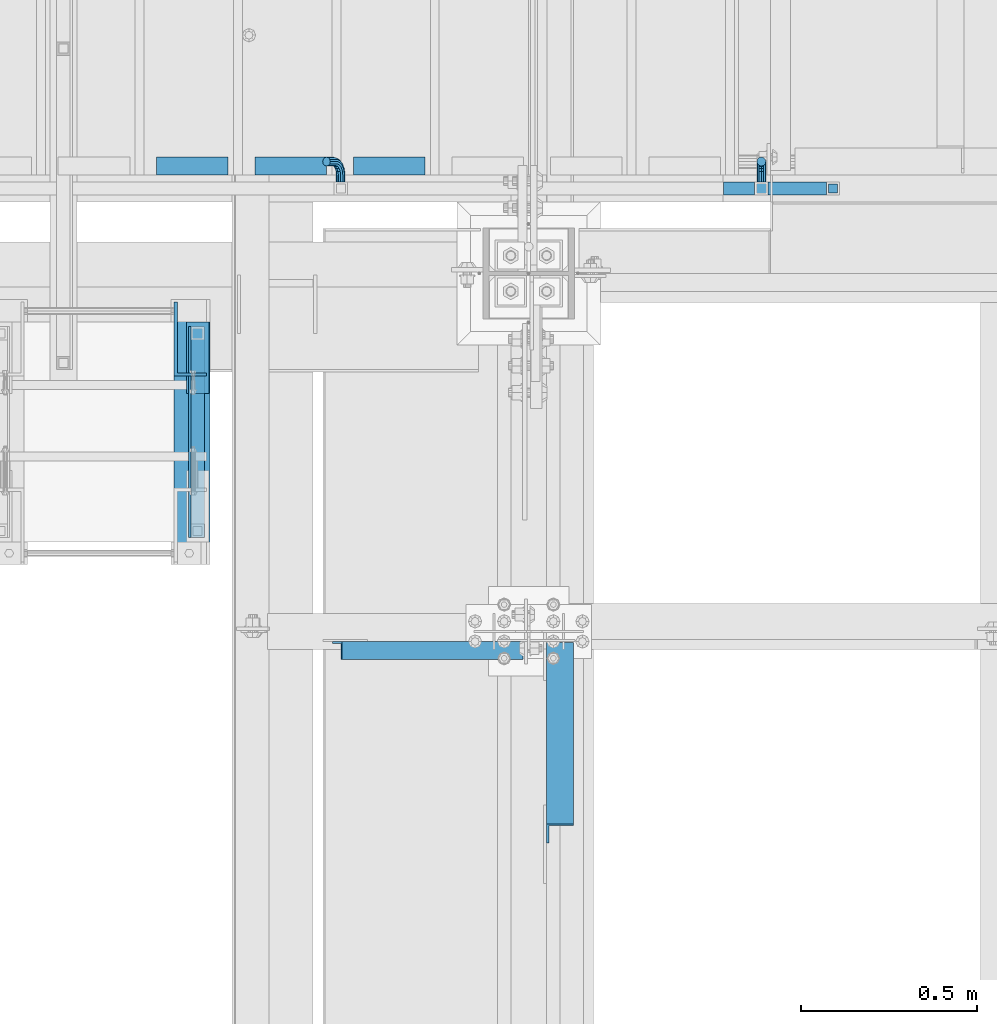
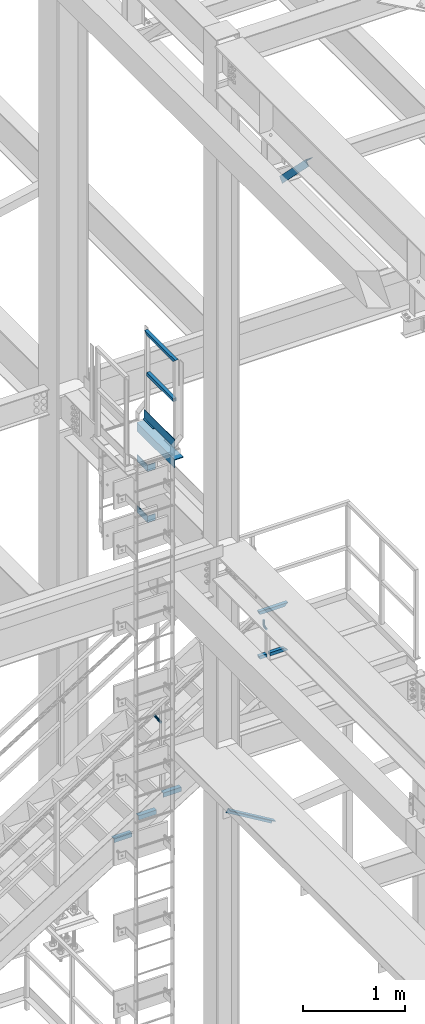
# One storey, part 2415 of 3843: 15 beams, 2 members, 7 elements without a shape of their own.
"""IFC2X3 building model written with IfcOpenShell, lengths in millimetres."""

from ifc_helpers import new_model, si_unit, frame, origin_with_axes, place, context, subcontext, project, spatial, faceted_brep, material, type_object, element, aggregate, save


model = new_model("IFC2X3")

# Units and contexts
model_context = context("Model", 3, precision=1e-05, world=origin_with_axes())
body_context = subcontext(model_context, "Body", "Model", "MODEL_VIEW")
ifc_project = project(units=[si_unit("LENGTHUNIT", "METRE", prefix="MILLI"), si_unit("AREAUNIT", "SQUARE_METRE"), si_unit("VOLUMEUNIT", "CUBIC_METRE"), si_unit("MASSUNIT", "GRAM", prefix="KILO"), si_unit("TIMEUNIT", "SECOND"), si_unit("PLANEANGLEUNIT", "RADIAN"), si_unit("SOLIDANGLEUNIT", "STERADIAN"), si_unit("THERMODYNAMICTEMPERATUREUNIT", "DEGREE_CELSIUS"), si_unit("LUMINOUSINTENSITYUNIT", "LUMEN")], contexts=[model_context])

# Site, building, storey
site_placement = place(None, origin_with_axes())
site = spatial("IfcSite", under=ifc_project, at=site_placement, CompositionType="ELEMENT")
building_placement = place(site_placement, origin_with_axes())
building = spatial("IfcBuilding", under=site, at=building_placement, Name="Undefined", CompositionType="ELEMENT")
storey_placement = place(building_placement, origin_with_axes())
storey = spatial("IfcBuildingStorey", under=building, at=storey_placement, Name="Undefined", CompositionType="ELEMENT", Elevation=0.0)

# Assembly, beams
assembly_1_placement = place(storey_placement, origin_with_axes())
assembly_1 = element("IfcElementAssembly", 1, at=assembly_1_placement, inside=storey, Name="LADDER", AssemblyPlace="NOTDEFINED", PredefinedType="RIGID_FRAME")
ifc_material_1 = material(Name="STEEL/A36")
beam_type_1 = type_object("IfcBeamType", PredefinedType="NOTDEFINED")
beam_1_placement = place(assembly_1_placement, frame((35574.2876302633, 89034.2801012867, 37797.6391357422), z_axis=(0.0, 0.0, 1.0), x_axis=(0.0, -1.0, 0.0)))
beam_1 = element("IfcBeam", 2, at=beam_1_placement, type_object=beam_type_1, material=ifc_material_1, Name="BENT_PLATE", context=body_context, shape_type="Brep", body=[
    faceted_brep([(0.0, -4.76250000000073, -38.0999999999985), (0.0, -4.76250000000073, 38.0999999999985), (0.0, 4.76250000000073, 38.0999999999985), (0.0, 4.76250000000073, -38.0999999999985), (200.223549612929, 4.76250007911585, 38.0999999999985), (200.223549612929, 4.76250007911585, -38.0999999999985), (209.748542611997, -4.76249991712393, -38.0999999999985), (209.748542611997, -4.76249991712393, 38.0999999999985), (200.223610287765, 87.3125000810978, 38.0999999999985), (200.223610287765, 87.3125000810978, -38.0999999999985), (209.748610287759, 87.3124930801496, 38.0999999999985), (209.748610287759, 87.3124930801496, -38.0999999999985)], [[[0, 1, 2, 3]], [[3, 2, 4, 5]], [[1, 0, 6, 7]], [[5, 4, 8, 9]], [[4, 2, 1, 7, 10, 8]], [[7, 6, 11, 10]], [[6, 0, 3, 5, 9, 11]], [[10, 11, 9, 8]]]),
])
beam_2_placement = place(assembly_1_placement, frame((35574.2876302804, 89034.2771574651, 37188.0390686035), z_axis=(0.0, 0.0, 1.0), x_axis=(0.0, -1.0, 0.0)))
beam_2 = element("IfcBeam", 3, at=beam_2_placement, type_object=beam_type_1, material=ifc_material_1, Name="BENT_PLATE", context=body_context, shape_type="Brep", body=[
    faceted_brep([(0.0, -4.76250000000073, -38.0999999999985), (0.0, -4.76250000000073, 38.0999999999985), (0.0, 4.76250000000073, 38.0999999999985), (0.0, 4.76250000000073, -38.0999999999985), (200.220605791415, 4.7625000627304, 38.0999999999985), (200.220605791415, 4.7625000627304, -38.0999999999985), (209.745598790527, -4.76249993429519, -38.0999999999985), (209.745598790527, -4.76249993429519, 38.0999999999985), (200.220666465641, 87.3125000643849, 38.0999999999985), (200.220666465641, 87.3125000643849, -38.0999999999985), (209.74566646562, 87.3124930635167, 38.0999999999985), (209.74566646562, 87.3124930635167, -38.0999999999985)], [[[0, 1, 2, 3]], [[3, 2, 4, 5]], [[1, 0, 6, 7]], [[5, 4, 8, 9]], [[4, 2, 1, 7, 10, 8]], [[7, 6, 11, 10]], [[6, 0, 3, 5, 9, 11]], [[10, 11, 9, 8]]]),
])
aggregate(assembly_1, [beam_1, beam_2])

assembly_2_placement = place(storey_placement, origin_with_axes())
assembly_2 = element("IfcElementAssembly", 4, at=assembly_2_placement, inside=storey, Name="RAIL", AssemblyPlace="NOTDEFINED", PredefinedType="RIGID_FRAME")
ifc_material_2 = material()
beam_type_2 = type_object("IfcBeamType", Name="HSS1-1/2X1-1/2X1/4", PredefinedType="NOTDEFINED")
beam_3_placement = place(assembly_2_placement, frame((35636.2, 88385.4515620002, 38851.6812479483), z_axis=(1.0, 0.0, 0.0), x_axis=(0.0, 1.0, 0.0)))
beam_3 = element("IfcBeam", 5, at=beam_3_placement, type_object=beam_type_2, material=ifc_material_2, Name="RAIL", ObjectType="HSS1-1/2X1-1/2X1/4", context=body_context, shape_type="Brep", body=[
    faceted_brep([(18.978796181982, 12.6999993299978, -12.6999993299978), (18.978796181982, -12.6999993299978, -12.6999993299978), (541.650771072775, -12.6999993299978, -12.6999993299978), (541.650771072775, 12.6999993299978, -12.6999993299978), (18.978796181982, -12.6999993299978, 12.6999993299978), (541.650771072775, -12.6999993299978, 12.6999993299978), (18.978796181982, 12.6999993299978, 12.6999993299978), (541.650771072775, 12.6999993299978, 12.6999993299978), (18.978796181982, 19.0499992350015, -19.0499992350015), (18.978796181982, 19.0499992350015, 19.0499992350015), (541.650771072775, 19.0499992350015, 19.0499992350015), (541.650771072775, 19.0499992350015, -19.0499992350015), (18.978796181982, -19.0499992350015, 19.0499992350015), (541.650771072775, -19.0499992350015, 19.0499992350015), (18.978796181982, -19.0499992350015, -19.0499992350015), (541.650771072775, -19.0499992350015, -19.0499992350015)], [[[0, 1, 2, 3]], [[1, 4, 5, 2]], [[4, 6, 7, 5]], [[6, 0, 3, 7]], [[8, 9, 10, 11]], [[9, 12, 13, 10]], [[12, 14, 15, 13]], [[14, 8, 11, 15]], [[13, 15, 11, 10], [5, 7, 3, 2]], [[14, 12, 9, 8], [6, 4, 1, 0]]]),
])
beam_4_placement = place(assembly_2_placement, frame((35636.2, 88385.4515620002, 39333.6859349483), z_axis=(1.0, 0.0, 0.0), x_axis=(0.0, 1.0, 0.0)))
beam_4 = element("IfcBeam", 6, at=beam_4_placement, type_object=beam_type_2, material=ifc_material_2, Name="RAIL", ObjectType="HSS1-1/2X1-1/2X1/4", context=body_context, shape_type="Brep", body=[
    faceted_brep([(-12.7712023829808, 12.6999993299978, -12.6999993299978), (12.6287962770293, -12.6999993299978, -12.6999993299978), (548.0007709778, -12.6999993299978, -12.6999993299978), (573.40076963781, 12.6999993299978, -12.6999993299978), (12.6287962770293, -12.6999993299978, 12.6999993299978), (548.0007709778, -12.6999993299978, 12.6999993299978), (-12.7712023829808, 12.6999993299978, 12.6999993299978), (573.40076963781, 12.6999993299978, 12.6999993299978), (-19.1212022879772, 19.0499992350015, -19.0499992350015), (-19.1212022879772, 19.0499992350015, 19.0499992350015), (579.750769542807, 19.0499992350015, 19.0499992350015), (579.750769542807, 19.0499992350015, -19.0499992350015), (18.978796181982, -19.0499992350015, 19.0499992350015), (541.650771072775, -19.0499992350015, 19.0499992350015), (18.978796181982, -19.0499992350015, -19.0499992350015), (541.650771072775, -19.0499992350015, -19.0499992350015)], [[[0, 1, 2, 3]], [[1, 4, 5, 2]], [[4, 6, 7, 5]], [[6, 0, 3, 7]], [[8, 9, 10, 11]], [[9, 12, 13, 10]], [[12, 14, 15, 13]], [[14, 8, 11, 15]], [[13, 15, 11, 10], [5, 7, 3, 2]], [[14, 12, 9, 8], [6, 4, 1, 0]]]),
])

assembly_3_placement = place(storey_placement, origin_with_axes())
assembly_3 = element("IfcElementAssembly", 7, at=assembly_3_placement, inside=storey, Name="RAIL", AssemblyPlace="NOTDEFINED", PredefinedType="RIGID_FRAME")
beam_5_placement = place(assembly_3_placement, frame((37236.4000002307, 89357.2000000455, 34670.999999695), z_axis=(0.0, 0.0, 1.0), x_axis=(1.0, 0.0, 0.0)))
beam_5 = element("IfcBeam", 8, at=beam_5_placement, type_object=beam_type_2, material=ifc_material_2, Name="RAIL", ObjectType="HSS1-1/2X1-1/2X1/4", context=body_context, shape_type="Brep", body=[
    faceted_brep([(19.0499992350015, 12.6999993299978, -12.6999993299978), (19.0499992350015, -12.6999993299978, -12.6999993299978), (215.899999329988, -12.6999993299978, -12.6999993299978), (215.899999329988, 12.6999993299978, -12.6999993299978), (19.0499992350015, -12.6999993299978, 12.6999993299978), (190.500000669992, -12.6999993299978, 12.6999993299978), (19.0499992350015, 12.6999993299978, 12.6999993299978), (190.500000669992, 12.6999993299978, 12.6999993299978), (19.0499992350015, 19.0499992350015, -19.0499992350015), (19.0499992350015, 19.0499992350015, 19.0499992350015), (184.150000764988, 19.0499992349942, 19.0499992350015), (222.249999234991, 19.0499992349942, -19.0499992350015), (19.0499992350015, -19.0499992350015, 19.0499992350015), (184.150000764988, -19.0499992349942, 19.0499992350015), (19.0499992350015, -19.0499992350015, -19.0499992350015), (222.249999234991, -19.0499992349942, -19.0499992350015)], [[[0, 1, 2, 3]], [[1, 4, 5, 2]], [[4, 6, 7, 5]], [[6, 0, 3, 7]], [[8, 9, 10, 11]], [[9, 12, 13, 10]], [[12, 14, 15, 13]], [[14, 8, 11, 15]], [[13, 15, 11, 10], [5, 7, 3, 2]], [[14, 12, 9, 8], [6, 4, 1, 0]]]),
])
beam_6_placement = place(assembly_3_placement, frame((37134.8000002412, 89357.2000000455, 34670.999999695), z_axis=(0.0, 0.0, 1.0), x_axis=(1.0, 0.0, 0.0)))
beam_6 = element("IfcBeam", 9, at=beam_6_placement, type_object=beam_type_2, material=ifc_material_2, Name="RAIL", ObjectType="HSS1-1/2X1-1/2X1/4", context=body_context, shape_type="Brep", body=[
    faceted_brep([(82.5500000532629, -19.0499999999993, 19.0499992350015), (82.5500000532629, -19.0499992350015, -19.0499992350015), (82.5500000532629, 19.0499992350015, -19.0499992350015), (82.5500000532629, 19.0499992350015, 19.0499992350015), (82.5500000532629, -12.6999993300014, 12.6999993299978), (82.5500000532629, 12.6999993300014, 12.6999993299978), (82.5500000532629, 12.6999993300014, -12.6999993299978), (82.5500000532629, -12.6999993300014, -12.6999993299978), (-5.45142736178605, 19.0499992350015, 19.0499992350015), (-5.45142736178605, -19.0499992350015, 19.0499992350015), (5.45142728947758, -19.0499992350015, -19.0499992350015), (5.45142728947758, 19.0499992350015, -19.0499992350015), (-3.63428487412239, 12.6999993299978, 12.6999993299978), (-3.63428487412239, -12.6999993299978, 12.6999993299978), (3.63428480181392, -12.6999993299978, -12.6999993299978), (3.63428480181392, 12.6999993299978, -12.6999993299978)], [[[0, 1, 2, 3], [4, 5, 6, 7]], [[8, 9, 0, 3]], [[10, 11, 2, 1]], [[9, 10, 1, 0]], [[11, 8, 3, 2]], [[10, 9, 8, 11], [12, 13, 14, 15]], [[14, 13, 4, 7]], [[15, 14, 7, 6]], [[12, 15, 6, 5]], [[13, 12, 5, 4]]]),
])
beam_7_placement = place(assembly_3_placement, frame((37439.6000002307, 89357.2000000455, 35204.399999695), z_axis=(0.0, 0.0, -1.0), x_axis=(-1.0, 0.0, 0.0)))
beam_7 = element("IfcBeam", 10, at=beam_7_placement, type_object=beam_type_2, material=ifc_material_2, Name="RAIL", ObjectType="HSS1-1/2X1-1/2X1/4", context=body_context, shape_type="Brep", body=[
    faceted_brep([(-12.6999993309546, 12.6999993299978, -12.6999993299978), (-12.6999993309546, -12.6999993299978, -12.6999993299978), (308.434284821327, -12.6999993299978, -12.6999993299978), (308.434284821327, 12.6999993299978, -12.6999993299978), (12.6999993290483, -12.6999993299978, 12.6999993299978), (301.165715145398, -12.6999993299978, 12.6999993299978), (12.6999993290483, 12.6999993299978, 12.6999993299978), (301.165715145398, 12.6999993299978, 12.6999993299978), (-19.0499992359546, 19.0499992350015, -19.0499992350015), (19.0499992350015, 19.0499992350015, 19.0499992350015), (299.348572657735, 19.0499992349942, 19.0499992350015), (310.251427308991, 19.0499992349942, -19.0499992350015), (19.0499992350015, -19.0499992350015, 19.0499992350015), (299.348572657735, -19.0499992349942, 19.0499992350015), (-19.0499992359546, -19.0499992350015, -19.0499992350015), (310.251427308991, -19.0499992349942, -19.0499992350015)], [[[0, 1, 2, 3]], [[1, 4, 5, 2]], [[4, 6, 7, 5]], [[6, 0, 3, 7]], [[8, 9, 10, 11]], [[9, 12, 13, 10]], [[12, 14, 15, 13]], [[14, 8, 11, 15]], [[13, 15, 11, 10], [5, 7, 3, 2]], [[14, 12, 9, 8], [6, 4, 1, 0]]]),
])

assembly_4_placement = place(storey_placement, origin_with_axes())
assembly_4 = element("IfcElementAssembly", 11, at=assembly_4_placement, inside=storey, Name="STAIR", AssemblyPlace="NOTDEFINED", PredefinedType="RIGID_FRAME")
beam_type_3 = type_object("IfcBeamType", Name="L2X2X3/16", PredefinedType="NOTDEFINED")
beam_8_placement = place(assembly_4_placement, frame((36281.8169176732, 89420.7000000434, 33361.5392857186), z_axis=(0.0, 1.0, 0.0), x_axis=(-1.0, 0.0, 0.0)))
beam_8 = element("IfcBeam", 12, at=beam_8_placement, type_object=beam_type_3, material=ifc_material_1, Name="ANGLE", ObjectType="L2X2X3/16", context=body_context, shape_type="Brep", body=[
    faceted_brep([(0.0, 25.4000000000015, -25.4000000000015), (0.0, 25.4000000000015, 25.4000000000015), (203.199999999997, 25.4000000000015, 25.4000000000015), (203.199999999997, 25.4000000000015, -25.4000000000015), (0.0, 20.6375000000007, 25.4000000000015), (203.199999999997, 20.6375000000007, 25.4000000000015), (0.0, 20.6375000000007, -20.6375000000007), (203.199999999997, 20.6375000000007, -20.6375000000007), (0.0, -25.4000000000015, -20.6375000000007), (203.199999999997, -25.4000000000015, -20.6375000000007), (0.0, -25.4000000000015, -25.4000000000015), (203.199999999997, -25.4000000000015, -25.4000000000015)], [[[0, 1, 2, 3]], [[1, 4, 5, 2]], [[4, 6, 7, 5]], [[6, 8, 9, 7]], [[8, 10, 11, 9]], [[10, 0, 3, 11]], [[5, 7, 9, 11, 3, 2]], [[10, 8, 6, 4, 1, 0]]]),
])
beam_9_placement = place(assembly_4_placement, frame((36002.4169176732, 89420.7000000434, 33187.3678571472), z_axis=(0.0, 1.0, 0.0), x_axis=(-1.0, 0.0, 0.0)))
beam_9 = element("IfcBeam", 13, at=beam_9_placement, type_object=beam_type_3, material=ifc_material_1, Name="ANGLE", ObjectType="L2X2X3/16", context=body_context, shape_type="Brep", body=[
    faceted_brep([(0.0, 25.4000000000015, -25.4000000000015), (0.0, 25.4000000000015, 25.4000000000015), (203.199999999997, 25.4000000000015, 25.4000000000015), (203.199999999997, 25.4000000000015, -25.4000000000015), (0.0, 20.6375000000007, 25.4000000000015), (203.199999999997, 20.6375000000007, 25.4000000000015), (0.0, 20.6375000000007, -20.6375000000007), (203.199999999997, 20.6375000000007, -20.6375000000007), (0.0, -25.4000000000015, -20.6375000000007), (203.199999999997, -25.4000000000015, -20.6375000000007), (0.0, -25.4000000000015, -25.4000000000015), (203.199999999997, -25.4000000000015, -25.4000000000015)], [[[0, 1, 2, 3]], [[1, 4, 5, 2]], [[4, 6, 7, 5]], [[6, 8, 9, 7]], [[8, 10, 11, 9]], [[10, 0, 3, 11]], [[5, 7, 9, 11, 3, 2]], [[10, 8, 6, 4, 1, 0]]]),
])
beam_10_placement = place(assembly_4_placement, frame((35723.0169176732, 89420.7000000434, 33013.1964285758), z_axis=(0.0, 1.0, 0.0), x_axis=(-1.0, 0.0, 0.0)))
beam_10 = element("IfcBeam", 14, at=beam_10_placement, type_object=beam_type_3, material=ifc_material_1, Name="ANGLE", ObjectType="L2X2X3/16", context=body_context, shape_type="Brep", body=[
    faceted_brep([(0.0, 25.4000000000015, -25.4000000000015), (0.0, 25.4000000000015, 25.4000000000015), (203.199999999997, 25.4000000000015, 25.4000000000015), (203.199999999997, 25.4000000000015, -25.4000000000015), (0.0, 20.6375000000007, 25.4000000000015), (203.199999999997, 20.6375000000007, 25.4000000000015), (0.0, 20.6375000000007, -20.6375000000007), (203.199999999997, 20.6375000000007, -20.6375000000007), (0.0, -25.4000000000015, -20.6375000000007), (203.199999999997, -25.4000000000015, -20.6375000000007), (0.0, -25.4000000000015, -25.4000000000015), (203.199999999997, -25.4000000000015, -25.4000000000015)], [[[0, 1, 2, 3]], [[1, 4, 5, 2]], [[4, 6, 7, 5]], [[6, 8, 9, 7]], [[8, 10, 11, 9]], [[10, 0, 3, 11]], [[5, 7, 9, 11, 3, 2]], [[10, 8, 6, 4, 1, 0]]]),
])
aggregate(assembly_4, [beam_8, beam_9, beam_10])

# Beam
beam_type_4 = type_object("IfcBeamType", PredefinedType="NOTDEFINED")
beam_11_placement = place(assembly_2_placement, frame((35636.2000000001, 88977.9023313522, 38289.7062479483), z_axis=(1.0, 0.0, 0.0), x_axis=(0.0, -1.0, 0.0)))
beam_11 = element("IfcBeam", 15, at=beam_11_placement, type_object=beam_type_4, material=ifc_material_1, context=body_context, shape_type="Brep", body=[
    faceted_brep([(0.0, 3.17500000000291, -31.75), (0.0, 3.17500000000291, 31.75), (203.199998088516, 3.17500000000291, 31.75), (203.199998088516, 3.17500000000291, -31.75), (0.0, -3.17500000000291, 31.75), (203.199998088516, -3.17500000000291, 31.75), (0.0, -3.17500000000291, -31.75), (203.199998088516, -3.17500000000291, -31.75)], [[[0, 1, 2, 3]], [[1, 4, 5, 2]], [[4, 6, 7, 5]], [[6, 0, 3, 7]], [[5, 7, 3, 2]], [[6, 4, 1, 0]]]),
])

beam_type_5 = type_object("IfcBeamType", PredefinedType="NOTDEFINED")
beam_12_placement = place(assembly_2_placement, frame((35613.9750007651, 88366.3303587565, 38356.3812479483), z_axis=(0.0, 0.0, 1.0), x_axis=(0.0, 1.0, 0.0)))
beam_12 = element("IfcBeam", 16, at=beam_12_placement, type_object=beam_type_5, material=ifc_material_1, Name="TOE_PLATE", context=body_context, shape_type="Brep", body=[
    faceted_brep([(0.0, 3.17500000000291, -50.8000000000029), (0.0, 3.17500000000291, 50.8000000000029), (598.864342436238, 3.17500000000291, 50.8000000000029), (598.864342436238, 3.17500000000291, -50.8000000000029), (0.0, -3.17500000000291, 50.8000000000029), (598.864342436238, -3.17500000000291, 50.8000000000029), (0.0, -3.17500000000291, -50.8000000000029), (598.864342436238, -3.17500000000291, -50.8000000000029)], [[[0, 1, 2, 3]], [[1, 4, 5, 2]], [[4, 6, 7, 5]], [[6, 0, 3, 7]], [[5, 7, 3, 2]], [[6, 4, 1, 0]]]),
])

aggregate(assembly_2, [beam_11, beam_12, beam_3, beam_4])

# Assembly, beam
assembly_5_placement = place(storey_placement, origin_with_axes())
assembly_5 = element("IfcElementAssembly", 17, at=assembly_5_placement, inside=storey, Name="ANGLE", AssemblyPlace="NOTDEFINED", PredefinedType="RIGID_FRAME")
beam_type_6 = type_object("IfcBeamType", Name="L4X4X3/8", PredefinedType="NOTDEFINED")
beam_13_placement = place(assembly_5_placement, frame((35620.3251798629, 89035.0477544666, 38172.287310791), z_axis=(0.0, 0.0, -1.0), x_axis=(0.0, -1.0, 0.0)))
beam_13 = element("IfcBeam", 18, at=beam_13_placement, type_object=beam_type_6, material=ifc_material_1, Name="ANGLE", ObjectType="L4X4X3/8", context=body_context, shape_type="Brep", body=[
    faceted_brep([(0.0, 50.8000000000029, -50.8000000000029), (0.0, 50.8000000000029, 50.8000000000029), (737.592200207029, 50.8000000000029, 50.8000000000029), (737.592200207029, 50.8000000000029, -50.8000000000029), (0.0, 41.2750000000015, 50.8000000000029), (737.592200207029, 41.2750000000015, 50.8000000000029), (0.0, 41.2749999999942, -41.2750000000015), (737.592200207029, 41.2750000000015, -41.2750000000015), (0.0, -50.8000000000029, -41.2750000000015), (737.592200207029, -50.8000000000029, -41.2750000000015), (0.0, -50.8000000000029, -50.8000000000029), (737.592200207029, -50.8000000000029, -50.8000000000029)], [[[0, 1, 2, 3]], [[1, 4, 5, 2]], [[4, 6, 7, 5]], [[6, 8, 9, 7]], [[8, 10, 11, 9]], [[10, 0, 3, 11]], [[5, 7, 9, 11, 3, 2]], [[10, 8, 6, 4, 1, 0]]]),
])
aggregate(assembly_5, [beam_13])

# Beam
beam_type_7 = type_object("IfcBeamType", PredefinedType="NOTDEFINED")
beam_14_placement = place(assembly_3_placement, frame((37236.4000002366, 89376.2500000455, 34956.7500000003), z_axis=(1.0, 0.0, 0.0), x_axis=(0.0, 1.0, 0.0)))
beam_14 = element("IfcBeam", 19, at=beam_14_placement, type_object=beam_type_7, material=ifc_material_1, Name="BRACKET ARM", context=body_context, shape_type="Brep", body=[
    faceted_brep([(0.0, -12.6999999999971, 0.0), (0.0, -10.9985226280696, -6.34999999999854), (19.0500015258731, -10.9985226280623, -6.34999999999854), (19.0500015258731, -12.6999999999971, -6.33008312433958e-10), (0.0, -6.35000000000582, -10.9985226280623), (19.0500015258731, -6.34999999999854, -10.9985226280623), (0.0, 0.0, -12.6999999999971), (19.0500015258731, 0.0, -12.6999999999971), (0.0, 6.35000000000582, -10.9985226280623), (19.0500015258731, 6.34999999999854, -10.9985226280623), (0.0, 10.9985226280696, -6.34999999999854), (19.0500015258731, 10.9985226280623, -6.34999999999854), (0.0, 12.6999999999971, 0.0), (19.0500015258731, 12.6999999999971, 0.0), (0.0, 10.9985226280696, 6.34999999999854), (19.0500015258731, 10.9985226280623, 6.34999999999854), (0.0, 6.35000000000582, 10.9985226280623), (19.0500015258731, 6.34999999999854, 10.9985226280623), (0.0, 0.0, 12.6999999999971), (19.0500015258731, 0.0, 12.6999999999971), (0.0, -6.35000000000582, 10.9985226280623), (19.0500015258731, -6.34999999999854, 10.9985226280623), (0.0, -10.9985226280696, 6.34999999999854), (19.0500015258731, -10.9985226280623, 6.34999999999854), (38.4903193060891, -8.8330803677236, -3.34694050252438e-10), (37.8391921052389, -7.26112024908798, 6.34999999974389), (36.0602795104642, -2.96644533684594, 10.9985226280041), (33.6302397149266, 2.90018969451194, 12.7000000002226), (31.2001999194181, 8.76682472604443, 10.9985226285644), (29.4212873247307, 13.061499638774, 6.35000000070431), (28.7701601240115, 14.6334597580644, 7.78527464717627e-10), (29.4212873248762, 13.0614996394288, -6.34999999929278), (31.2001999196509, 8.76682472718676, -10.9985226275603), (33.6302397151885, 2.90018969582889, -12.6999999997788), (36.0602795106824, -2.96644533571089, -10.9985226281206), (37.8391921053699, -7.26112024843314, -6.35000000026048), (53.7678987435793, 3.38210125690239, -6.3499999994383), (54.9710249311902, 2.17897506880399, 5.0931703299284e-10), (50.4808968708676, 6.66910312997061, -10.9985226273784), (45.9907688103704, 11.1592311906061, -12.6999999991458), (41.5006407498004, 15.6493592510378, -10.9985226270364), (38.213638876914, 18.9363611235749, -6.34999999884167), (37.0105126890558, 20.1394873109457, 1.20053300634027e-09), (38.2136388766667, 18.9363611228473, 6.35000000115542), (41.5006407493784, 15.6493592497718, 10.9985226290883), (45.9907688098756, 11.1592311891436, 12.7000000008557), (50.4808968704456, 6.66910312870459, 10.9985226287463), (53.7678987433319, 3.38210125617479, 6.35000000055879), (64.4111202489148, 19.3108078951118, -6.34999999821594), (65.9830803677178, 18.6596806939051, 1.77533365786076e-09), (60.1164453365491, 21.0897204901557, -10.9985226262725), (54.2498103051475, 23.5197602857806, -12.6999999981927), (48.3831752736587, 25.9498000811873, -10.9985226262434), (44.0885003610601, 27.7287126756128, -6.34999999817228), (42.516540241937, 28.3798398759754, 1.83354131877422e-09), (44.08850036074, 27.7287126747688, 6.35000000183209), (48.3831752731057, 25.9498000797321, 10.9985226298813), (54.2498103045073, 23.5197602840999, 12.7000000018088), (60.1164453359961, 21.0897204886933, 10.9985226298522), (64.4111202485947, 19.3108078942678, 6.35000000178115), (68.1485226282239, 38.0999984746086, -6.3499999967753), (69.8499999999913, 38.0999984741211, 2.92493496090174e-09), (63.500000000291, 38.0999984749651, -10.9985226249628), (57.1500000003434, 38.0999984750961, -12.6999999970722), (50.8000000002939, 38.0999984749651, -10.998522625312), (46.1514773720992, 38.0999984746086, -6.34999999737192), (44.4499999999971, 38.0999984741211, 2.58296495303512e-09), (46.1514773717645, 38.0999984736336, 6.35000000262517), (50.7999999996973, 38.0999984732771, 10.9985226308127), (57.1499999996449, 38.0999984731461, 12.700000002922), (63.4999999996944, 38.0999984732771, 10.9985226311619), (68.1485226278892, 38.0999984736336, 6.35000000322179), (68.1485226280638, 76.2000000002372, -6.34999999414867), (69.8499999999913, 76.199999999757, 5.84986992180347e-09), (63.5, 76.200000000601, -10.9985226222125), (57.1499999999942, 76.2000000007247, -12.6999999941472), (50.7999999999884, 76.200000000601, -10.9985226222125), (46.1514773719246, 76.2000000002372, -6.34999999414867), (44.4499999999971, 76.199999999757, 5.84986992180347e-09), (46.1514773719246, 76.1999999992695, 6.35000000584841), (50.7999999999884, 76.1999999989057, 10.9985226339122), (57.1499999999942, 76.199999998782, 12.700000005847), (63.5, 76.1999999989057, 10.9985226339122), (68.1485226280638, 76.1999999992695, 6.35000000584841)], [[[0, 1, 2, 3]], [[1, 4, 5, 2]], [[4, 6, 7, 5]], [[6, 8, 9, 7]], [[8, 10, 11, 9]], [[10, 12, 13, 11]], [[12, 14, 15, 13]], [[14, 16, 17, 15]], [[16, 18, 19, 17]], [[18, 20, 21, 19]], [[20, 22, 23, 21]], [[22, 0, 3, 23]], [[22, 20, 18, 16, 14, 12, 10, 8, 6, 4, 1, 0]], [[23, 3, 24, 25]], [[21, 23, 25, 26]], [[19, 21, 26, 27]], [[17, 19, 27, 28]], [[15, 17, 28, 29]], [[13, 15, 29, 30]], [[11, 13, 30, 31]], [[9, 11, 31, 32]], [[7, 9, 32, 33]], [[5, 7, 33, 34]], [[2, 5, 34, 35]], [[3, 2, 35, 24]], [[35, 36, 37, 24]], [[34, 38, 36, 35]], [[33, 39, 38, 34]], [[32, 40, 39, 33]], [[31, 41, 40, 32]], [[30, 42, 41, 31]], [[29, 43, 42, 30]], [[28, 44, 43, 29]], [[27, 45, 44, 28]], [[26, 46, 45, 27]], [[25, 47, 46, 26]], [[24, 37, 47, 25]], [[36, 48, 49, 37]], [[38, 50, 48, 36]], [[39, 51, 50, 38]], [[40, 52, 51, 39]], [[41, 53, 52, 40]], [[42, 54, 53, 41]], [[43, 55, 54, 42]], [[44, 56, 55, 43]], [[45, 57, 56, 44]], [[46, 58, 57, 45]], [[47, 59, 58, 46]], [[37, 49, 59, 47]], [[48, 60, 61, 49]], [[50, 62, 60, 48]], [[51, 63, 62, 50]], [[52, 64, 63, 51]], [[53, 65, 64, 52]], [[54, 66, 65, 53]], [[55, 67, 66, 54]], [[56, 68, 67, 55]], [[57, 69, 68, 56]], [[58, 70, 69, 57]], [[59, 71, 70, 58]], [[49, 61, 71, 59]], [[61, 60, 72, 73]], [[60, 62, 74, 72]], [[62, 63, 75, 74]], [[63, 64, 76, 75]], [[64, 65, 77, 76]], [[65, 66, 78, 77]], [[66, 67, 79, 78]], [[67, 68, 80, 79]], [[68, 69, 81, 80]], [[69, 70, 82, 81]], [[70, 71, 83, 82]], [[71, 61, 73, 83]], [[74, 75, 76, 77, 78, 79, 80, 81, 82, 83, 73, 72]]]),
])

beam_15_placement = place(assembly_3_placement, frame((36042.3458144613, 89376.2500000455, 34258.7481354453), z_axis=(0.848616882600527, 0.0, 0.529007926750974), x_axis=(0.0, 1.0, 0.0)))
beam_15 = element("IfcBeam", 20, at=beam_15_placement, type_object=beam_type_7, material=ifc_material_1, Name="BRACKET ARM", context=body_context, shape_type="Brep", body=[
    faceted_brep([(0.0, -12.6999999999971, 0.0), (0.0, -10.9985226280696, -6.34999999999854), (19.0500015258731, -10.9985226280623, -6.34999999999854), (19.0500015258731, -12.6999999999971, -6.33008312433958e-10), (0.0, -6.35000000000582, -10.9985226280623), (19.0500015258731, -6.34999999999854, -10.9985226280623), (0.0, 0.0, -12.6999999999971), (19.0500015258731, 0.0, -12.6999999999971), (0.0, 6.35000000000582, -10.9985226280623), (19.0500015258731, 6.34999999999854, -10.9985226280623), (0.0, 10.9985226280696, -6.34999999999854), (19.0500015258731, 10.9985226280623, -6.34999999999854), (0.0, 12.6999999999971, 0.0), (19.0500015258731, 12.6999999999971, 0.0), (0.0, 10.9985226280696, 6.34999999999854), (19.0500015258731, 10.9985226280623, 6.34999999999854), (0.0, 6.35000000000582, 10.9985226280623), (19.0500015258731, 6.34999999999854, 10.9985226280623), (0.0, 0.0, 12.6999999999971), (19.0500015258731, 0.0, 12.6999999999971), (0.0, -6.35000000000582, 10.9985226280623), (19.0500015258731, -6.34999999999854, 10.9985226280623), (0.0, -10.9985226280696, 6.34999999999854), (19.0500015258731, -10.9985226280623, 6.34999999999854), (38.4903193060891, -8.8330803677236, -3.34694050252438e-10), (37.8391921052389, -7.26112024908798, 6.34999999974389), (36.0602795104642, -2.96644533684594, 10.9985226280041), (33.6302397149266, 2.90018969451194, 12.7000000002226), (31.2001999194181, 8.76682472604443, 10.9985226285644), (29.4212873247307, 13.061499638774, 6.35000000070431), (28.7701601240115, 14.6334597580644, 7.78527464717627e-10), (29.4212873248762, 13.0614996394288, -6.34999999929278), (31.2001999196509, 8.76682472718676, -10.9985226275603), (33.6302397151885, 2.90018969582889, -12.6999999997788), (36.0602795106824, -2.96644533571089, -10.9985226281206), (37.8391921053699, -7.26112024843314, -6.35000000026048), (53.7678987435793, 3.38210125690239, -6.3499999994383), (54.9710249311902, 2.17897506880399, 5.0931703299284e-10), (50.4808968708676, 6.66910312997061, -10.9985226273784), (45.9907688103704, 11.1592311906061, -12.6999999991458), (41.5006407498004, 15.6493592510378, -10.9985226270364), (38.213638876914, 18.9363611235749, -6.34999999884167), (37.0105126890558, 20.1394873109457, 1.20053300634027e-09), (38.2136388766667, 18.9363611228473, 6.35000000115542), (41.5006407493784, 15.6493592497718, 10.9985226290883), (45.9907688098756, 11.1592311891436, 12.7000000008557), (50.4808968704456, 6.66910312870459, 10.9985226287463), (53.7678987433319, 3.38210125617479, 6.35000000055879), (64.4111202489148, 19.3108078951118, -6.34999999821594), (65.9830803677178, 18.6596806939051, 1.77533365786076e-09), (60.1164453365491, 21.0897204901557, -10.9985226262725), (54.2498103051475, 23.5197602857806, -12.6999999981927), (48.3831752736587, 25.9498000811873, -10.9985226262434), (44.0885003610601, 27.7287126756128, -6.34999999817228), (42.516540241937, 28.3798398759754, 1.83354131877422e-09), (44.08850036074, 27.7287126747688, 6.35000000183209), (48.3831752731057, 25.9498000797321, 10.9985226298813), (54.2498103045073, 23.5197602840999, 12.7000000018088), (60.1164453359961, 21.0897204886933, 10.9985226298522), (64.4111202485947, 19.3108078942678, 6.35000000178115), (68.1485226282239, 38.0999984746086, -6.3499999967753), (69.8499999999913, 38.0999984741211, 2.92493496090174e-09), (63.500000000291, 38.0999984749651, -10.9985226249628), (57.1500000003434, 38.0999984750961, -12.6999999970722), (50.8000000002939, 38.0999984749651, -10.998522625312), (46.1514773720992, 38.0999984746086, -6.34999999737192), (44.4499999999971, 38.0999984741211, 2.58296495303512e-09), (46.1514773717645, 38.0999984736336, 6.35000000262517), (50.7999999996973, 38.0999984732771, 10.9985226308127), (57.1499999996449, 38.0999984731461, 12.700000002922), (63.4999999996944, 38.0999984732771, 10.9985226311619), (68.1485226278892, 38.0999984736336, 6.35000000322179), (68.1485226280638, 76.2000000002372, -6.34999999414867), (69.8499999999913, 76.199999999757, 5.84986992180347e-09), (63.5, 76.200000000601, -10.9985226222125), (57.1499999999942, 76.2000000007247, -12.6999999941472), (50.7999999999884, 76.200000000601, -10.9985226222125), (46.1514773719246, 76.2000000002372, -6.34999999414867), (44.4499999999971, 76.199999999757, 5.84986992180347e-09), (46.1514773719246, 76.1999999992695, 6.35000000584841), (50.7999999999884, 76.1999999989057, 10.9985226339122), (57.1499999999942, 76.199999998782, 12.700000005847), (63.5, 76.1999999989057, 10.9985226339122), (68.1485226280638, 76.1999999992695, 6.35000000584841)], [[[0, 1, 2, 3]], [[1, 4, 5, 2]], [[4, 6, 7, 5]], [[6, 8, 9, 7]], [[8, 10, 11, 9]], [[10, 12, 13, 11]], [[12, 14, 15, 13]], [[14, 16, 17, 15]], [[16, 18, 19, 17]], [[18, 20, 21, 19]], [[20, 22, 23, 21]], [[22, 0, 3, 23]], [[22, 20, 18, 16, 14, 12, 10, 8, 6, 4, 1, 0]], [[23, 3, 24, 25]], [[21, 23, 25, 26]], [[19, 21, 26, 27]], [[17, 19, 27, 28]], [[15, 17, 28, 29]], [[13, 15, 29, 30]], [[11, 13, 30, 31]], [[9, 11, 31, 32]], [[7, 9, 32, 33]], [[5, 7, 33, 34]], [[2, 5, 34, 35]], [[3, 2, 35, 24]], [[35, 36, 37, 24]], [[34, 38, 36, 35]], [[33, 39, 38, 34]], [[32, 40, 39, 33]], [[31, 41, 40, 32]], [[30, 42, 41, 31]], [[29, 43, 42, 30]], [[28, 44, 43, 29]], [[27, 45, 44, 28]], [[26, 46, 45, 27]], [[25, 47, 46, 26]], [[24, 37, 47, 25]], [[36, 48, 49, 37]], [[38, 50, 48, 36]], [[39, 51, 50, 38]], [[40, 52, 51, 39]], [[41, 53, 52, 40]], [[42, 54, 53, 41]], [[43, 55, 54, 42]], [[44, 56, 55, 43]], [[45, 57, 56, 44]], [[46, 58, 57, 45]], [[47, 59, 58, 46]], [[37, 49, 59, 47]], [[48, 60, 61, 49]], [[50, 62, 60, 48]], [[51, 63, 62, 50]], [[52, 64, 63, 51]], [[53, 65, 64, 52]], [[54, 66, 65, 53]], [[55, 67, 66, 54]], [[56, 68, 67, 55]], [[57, 69, 68, 56]], [[58, 70, 69, 57]], [[59, 71, 70, 58]], [[49, 61, 71, 59]], [[61, 60, 72, 73]], [[60, 62, 74, 72]], [[62, 63, 75, 74]], [[63, 64, 76, 75]], [[64, 65, 77, 76]], [[65, 66, 78, 77]], [[66, 67, 79, 78]], [[67, 68, 80, 79]], [[68, 69, 81, 80]], [[69, 70, 82, 81]], [[70, 71, 83, 82]], [[71, 61, 73, 83]], [[74, 75, 76, 77, 78, 79, 80, 81, 82, 83, 73, 72]]]),
])

aggregate(assembly_3, [beam_14, beam_5, beam_15, beam_6, beam_7])

# Assembly, member
assembly_6_placement = place(storey_placement, origin_with_axes())
assembly_6 = element("IfcElementAssembly", 21, at=assembly_6_placement, inside=storey, Name="ANGLE", AssemblyPlace="NOTDEFINED", PredefinedType="RIGID_FRAME")
ifc_material_3 = material(Name="STEEL/A572-50")
member_type_1 = type_object("IfcMemberType", Name="L2X2X1/4", PredefinedType="NOTDEFINED")
member_1_placement = place(assembly_6_placement, frame((36032.7062481198, 88045.9250000001, 34001.5027629153), z_axis=(0.0, -1.0, 0.0), x_axis=(0.858158898344811, 0.0, -0.513384169206278)))
member_1 = element("IfcMember", 22, at=member_1_placement, type_object=member_type_1, material=ifc_material_3, Name="ANGLE", ObjectType="L2X2X1/4", context=body_context, shape_type="Brep", body=[
    faceted_brep([(0.0, 25.4000000000015, -25.4000000000015), (0.0, 25.4000000000015, 25.4000000000015), (598.473132324763, 25.3999999988228, 25.3999999999942), (598.473132324763, 25.3999999988228, -25.3999999999942), (0.0, 19.0500000000029, 25.4000000000015), (598.473132324745, 19.0499999988242, 25.3999999999942), (0.0, 19.0500000000029, -19.0499999999993), (598.473132324745, 19.0499999988242, -19.0500000000029), (0.0, -25.4000000000015, -19.0499999999993), (598.473132324661, -25.4000000011511, -19.0500000000029), (0.0, -25.4000000000015, -25.4000000000015), (598.473132324661, -25.4000000011511, -25.3999999999942)], [[[0, 1, 2, 3]], [[1, 4, 5, 2]], [[4, 6, 7, 5]], [[6, 8, 9, 7]], [[8, 10, 11, 9]], [[10, 0, 3, 11]], [[5, 7, 9, 11, 3, 2]], [[10, 8, 6, 4, 1, 0]]]),
])
aggregate(assembly_6, [member_1])

assembly_7_placement = place(storey_placement, origin_with_axes())
assembly_7 = element("IfcElementAssembly", 23, at=assembly_7_placement, inside=storey, Name="ANGLE", AssemblyPlace="NOTDEFINED", PredefinedType="RIGID_FRAME")
member_type_2 = type_object("IfcMemberType", Name="L3X3X1/4", PredefinedType="NOTDEFINED")
member_2_placement = place(assembly_7_placement, frame((36664.9, 88099.9, 41300.4), z_axis=(0.0, -0.707106781186548, -0.707106781186548), x_axis=(0.0, -0.707106781186682, 0.707106781186413)))
member_2 = element("IfcMember", 24, at=member_2_placement, type_object=member_type_2, material=ifc_material_3, Name="ANGLE", ObjectType="L3X3X1/4", context=body_context, shape_type="Brep", body=[
    faceted_brep([(83.0012806675732, 38.0999999999985, -38.0999999999058), (83.0012806675732, -38.0999999999985, -38.0999999999058), (83.0012806675804, -38.0999999999985, -31.7499999999254), (83.0012806675804, 31.75, -31.7499999999254), (83.0012806675804, 31.75, 38.0999999999058), (83.0012806675804, 38.0999999999985, 38.0999999999058), (810.534203444928, 31.75, 38.0999999999112), (810.534203444928, 38.0999999999985, 38.0999999999112), (810.534203444538, 38.0999999999985, -38.099999999904), (810.534203444538, -38.0999999999985, -38.099999999904), (810.534203444575, -38.0999999999985, -31.7499999999272), (810.534203444575, 31.75, -31.7499999999272)], [[[0, 1, 2, 3, 4, 5]], [[5, 4, 6, 7]], [[0, 5, 7, 8]], [[1, 0, 8, 9]], [[2, 1, 9, 10]], [[3, 2, 10, 11]], [[4, 3, 11, 6]], [[10, 9, 8, 7, 6, 11]]]),
])
aggregate(assembly_7, [member_2])

save(model, "model.ifc")
